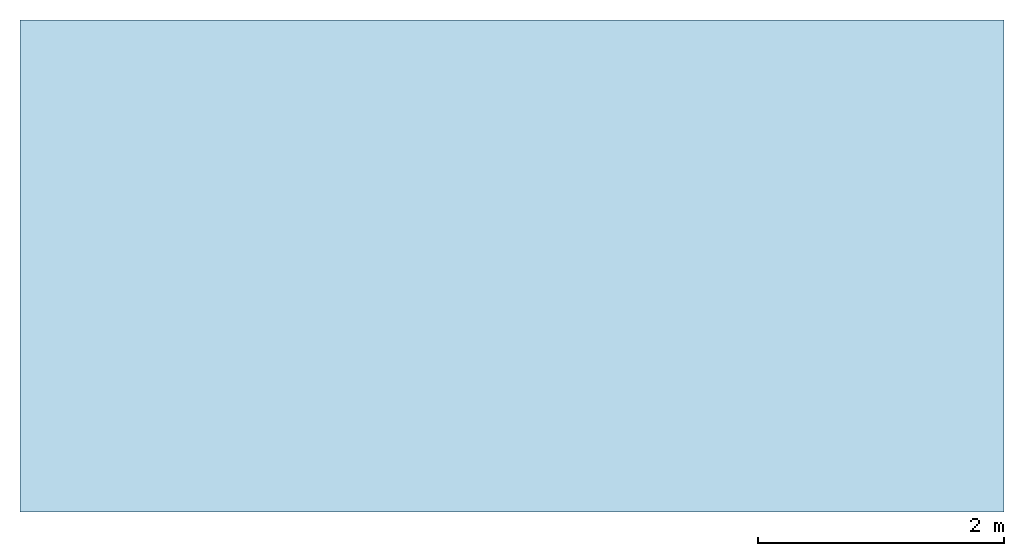
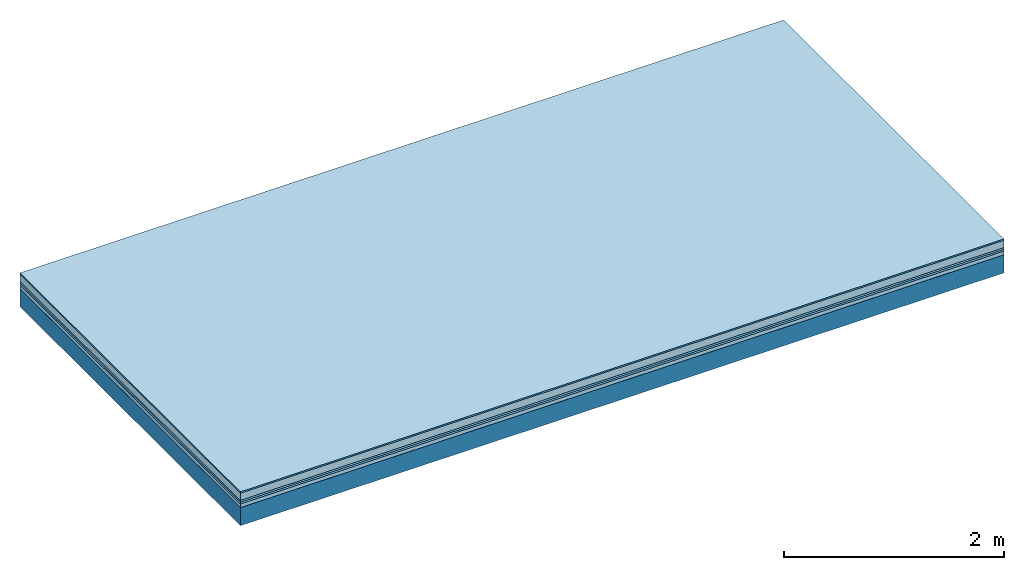
# One storey: 6 plates, 1 member, 1 element without a shape of its own.
"""IFC4 building model written with IfcOpenShell, lengths in metres."""

from ifc_helpers import new_model, si_unit, derived_unit, direction, frame, frame_2d, origin, origin_with_axes, place, context, project, spatial, rectangle, extrude, material, layer, layer_set, type_object, element, aggregate, save


model = new_model("IFC4")

# Units and contexts
plan_context = context("Plan", 3, precision=1e-05, world=origin(), true_north=direction((0.0, 1.0)))
model_context = context("Model", 3, precision=1e-05, world=origin(), true_north=direction((0.0, 1.0)))
ifc_project = project(units=[si_unit("LENGTHUNIT", "METRE"), derived_unit("SOUNDPRESSUREUNIT", [(si_unit("PRESSUREUNIT", "PASCAL", prefix="MICRO"), 0)]), si_unit("ENERGYUNIT", "JOULE", prefix="MEGA"), si_unit("MASSUNIT", "GRAM", prefix="KILO"), derived_unit("THERMALTRANSMITTANCEUNIT", [(si_unit("POWERUNIT", "WATT"), 1), (si_unit("AREAUNIT", "SQUARE_METRE"), -1), (si_unit("THERMODYNAMICTEMPERATUREUNIT", "KELVIN"), -1)]), derived_unit("AREADENSITYUNIT", [(si_unit("MASSUNIT", "GRAM", prefix="KILO"), 1), (si_unit("AREAUNIT", "SQUARE_METRE"), -1)]), derived_unit("USERDEFINED", [(si_unit("ENERGYUNIT", "JOULE", prefix="MEGA"), 1), (si_unit("AREAUNIT", "SQUARE_METRE"), -1)])], contexts=[plan_context, model_context])

# Site, building, storey
site = spatial("IfcSite", under=ifc_project)
building_placement = place(None, origin())
building = spatial("IfcBuilding", under=site, at=building_placement)
storey_placement = place(building_placement, origin())
storey = spatial("IfcBuildingStorey", under=building, at=storey_placement)

# Slab, member, plates
ifc_material_1 = material(Category="11.013")
ifc_layer_1 = layer(ifc_material_1, 0.015, Name="Flooring")
ifc_material_2 = material(Name="Cement screed", Category="04.006")
ifc_layer_2 = layer(ifc_material_2, 0.08, Name="On-material")
ifc_material_3 = material(Name="Wood fiber generic product", Category="10.009")
ifc_layer_3 = layer(ifc_material_3, 0.02, Name="Impact sound insulation")
ifc_material_4 = material()
ifc_layer_4 = layer(ifc_material_4, 0.02, Name="Additional insulation")
ifc_material_5 = material(Name="Cement panels, glued on sub-floor", Category="02.007")
ifc_layer_5 = layer(ifc_material_5, 0.04, Name="on Supporting structure")
ifc_material_6 = material(Name="protection", Category="09.007")
ifc_layer_6 = layer(ifc_material_6, 0.0005, Name="Sub-floor")
ifc_material_7 = material(Name="no composite action")
ifc_layer_7 = layer(ifc_material_7, 0.0, Name="Bond")
ifc_layer_8 = layer(None, 0.2, Name="Supporting structure")
ifc_layer_set = layer_set([ifc_layer_1, ifc_layer_2, ifc_layer_3, ifc_layer_4, ifc_layer_5, ifc_layer_6, ifc_layer_7, ifc_layer_8])
slab_type = type_object("IfcSlabType", Name="A2091", PredefinedType="NOTDEFINED", material=ifc_layer_set)
slab_placement = place(None, frame((0.0, 0.0, 0.0), z_axis=(0.0, 0.0, -1.0), x_axis=(1.0, 0.0, 0.0)))
slab = element("IfcSlab", 1, at=slab_placement, inside=storey, type_object=slab_type, material=ifc_layer_set, Name="Slab #1")
ifc_material_8 = material(Name="Solid timber panel")
member_placement = place(slab_placement, origin())
member = element("IfcMember", 2, at=member_placement, material=ifc_material_8, Name="Supporting structure", context=plan_context, shape_type="SweptSolid", body=[
    extrude(rectangle(XDim=1.0, YDim=0.2, at=frame_2d((0.5, 0.1), x_axis=(1.0, 0.0))), frame((0.0, 4.0, 0.1755), z_axis=(0.0, -1.0, 0.0), x_axis=(1.0, 0.0, 0.0)), (0.0, 0.0, 1.0), 4.0),
    extrude(rectangle(XDim=1.0, YDim=0.2, at=frame_2d((0.5, 0.1), x_axis=(1.0, 0.0))), frame((1.0, 4.0, 0.1755), z_axis=(0.0, -1.0, 0.0), x_axis=(1.0, 0.0, 0.0)), (0.0, 0.0, 1.0), 4.0),
    extrude(rectangle(XDim=1.0, YDim=0.2, at=frame_2d((0.5, 0.1), x_axis=(1.0, 0.0))), frame((2.0, 4.0, 0.1755), z_axis=(0.0, -1.0, 0.0), x_axis=(1.0, 0.0, 0.0)), (0.0, 0.0, 1.0), 4.0),
    extrude(rectangle(XDim=1.0, YDim=0.2, at=frame_2d((0.5, 0.1), x_axis=(1.0, 0.0))), frame((3.0, 4.0, 0.1755), z_axis=(0.0, -1.0, 0.0), x_axis=(1.0, 0.0, 0.0)), (0.0, 0.0, 1.0), 4.0),
    extrude(rectangle(XDim=1.0, YDim=0.2, at=frame_2d((0.5, 0.1), x_axis=(1.0, 0.0))), frame((4.0, 4.0, 0.1755), z_axis=(0.0, -1.0, 0.0), x_axis=(1.0, 0.0, 0.0)), (0.0, 0.0, 1.0), 4.0),
    extrude(rectangle(XDim=1.0, YDim=0.2, at=frame_2d((0.5, 0.1), x_axis=(1.0, 0.0))), frame((5.0, 4.0, 0.1755), z_axis=(0.0, -1.0, 0.0), x_axis=(1.0, 0.0, 0.0)), (0.0, 0.0, 1.0), 4.0),
    extrude(rectangle(XDim=1.0, YDim=0.2, at=frame_2d((0.5, 0.1), x_axis=(1.0, 0.0))), frame((6.0, 4.0, 0.1755), z_axis=(0.0, -1.0, 0.0), x_axis=(1.0, 0.0, 0.0)), (0.0, 0.0, 1.0), 4.0),
    extrude(rectangle(XDim=1.0, YDim=0.2, at=frame_2d((0.5, 0.1), x_axis=(1.0, 0.0))), frame((7.0, 4.0, 0.1755), z_axis=(0.0, -1.0, 0.0), x_axis=(1.0, 0.0, 0.0)), (0.0, 0.0, 1.0), 4.0),
])
plate_1_placement = place(slab_placement, origin())
plate_1 = element("IfcPlate", 3, at=plate_1_placement, material=ifc_material_1, Name="Flooring", context=plan_context, shape_type="SweptSolid", body=[
    extrude(rectangle(XDim=8.0, YDim=4.0, at=frame_2d((4.0, 2.0), x_axis=(1.0, 0.0))), origin_with_axes(), (0.0, 0.0, 1.0), 0.015),
])
plate_2_placement = place(slab_placement, origin())
plate_2 = element("IfcPlate", 4, at=plate_2_placement, material=ifc_material_2, Name="On-material", context=plan_context, shape_type="SweptSolid", body=[
    extrude(rectangle(XDim=8.0, YDim=4.0, at=frame_2d((4.0, 2.0), x_axis=(1.0, 0.0))), frame((0.0, 0.0, 0.015), z_axis=(0.0, 0.0, 1.0), x_axis=(1.0, 0.0, 0.0)), (0.0, 0.0, 1.0), 0.08),
])
plate_3_placement = place(slab_placement, origin())
plate_3 = element("IfcPlate", 5, at=plate_3_placement, material=ifc_material_3, Name="Impact sound insulation", context=plan_context, shape_type="SweptSolid", body=[
    extrude(rectangle(XDim=8.0, YDim=4.0, at=frame_2d((4.0, 2.0), x_axis=(1.0, 0.0))), frame((0.0, 0.0, 0.095), z_axis=(0.0, 0.0, 1.0), x_axis=(1.0, 0.0, 0.0)), (0.0, 0.0, 1.0), 0.02),
])
plate_4_placement = place(slab_placement, origin())
plate_4 = element("IfcPlate", 6, at=plate_4_placement, material=ifc_material_4, Name="Additional insulation", context=plan_context, shape_type="SweptSolid", body=[
    extrude(rectangle(XDim=8.0, YDim=4.0, at=frame_2d((4.0, 2.0), x_axis=(1.0, 0.0))), frame((0.0, 0.0, 0.115), z_axis=(0.0, 0.0, 1.0), x_axis=(1.0, 0.0, 0.0)), (0.0, 0.0, 1.0), 0.02),
])
plate_5_placement = place(slab_placement, origin())
plate_5 = element("IfcPlate", 7, at=plate_5_placement, material=ifc_material_5, Name="on Supporting structure", context=plan_context, shape_type="SweptSolid", body=[
    extrude(rectangle(XDim=8.0, YDim=4.0, at=frame_2d((4.0, 2.0), x_axis=(1.0, 0.0))), frame((0.0, 0.0, 0.135), z_axis=(0.0, 0.0, 1.0), x_axis=(1.0, 0.0, 0.0)), (0.0, 0.0, 1.0), 0.04),
])
plate_6_placement = place(slab_placement, origin())
plate_6 = element("IfcPlate", 8, at=plate_6_placement, material=ifc_material_6, Name="Sub-floor", context=plan_context, shape_type="SweptSolid", body=[
    extrude(rectangle(XDim=8.0, YDim=4.0, at=frame_2d((4.0, 2.0), x_axis=(1.0, 0.0))), frame((0.0, 0.0, 0.175), z_axis=(0.0, 0.0, 1.0), x_axis=(1.0, 0.0, 0.0)), (0.0, 0.0, 1.0), 0.0005),
])
aggregate(slab, [plate_1, plate_2, plate_3, plate_4, plate_5, plate_6, member])

save(model, "model.ifc")
